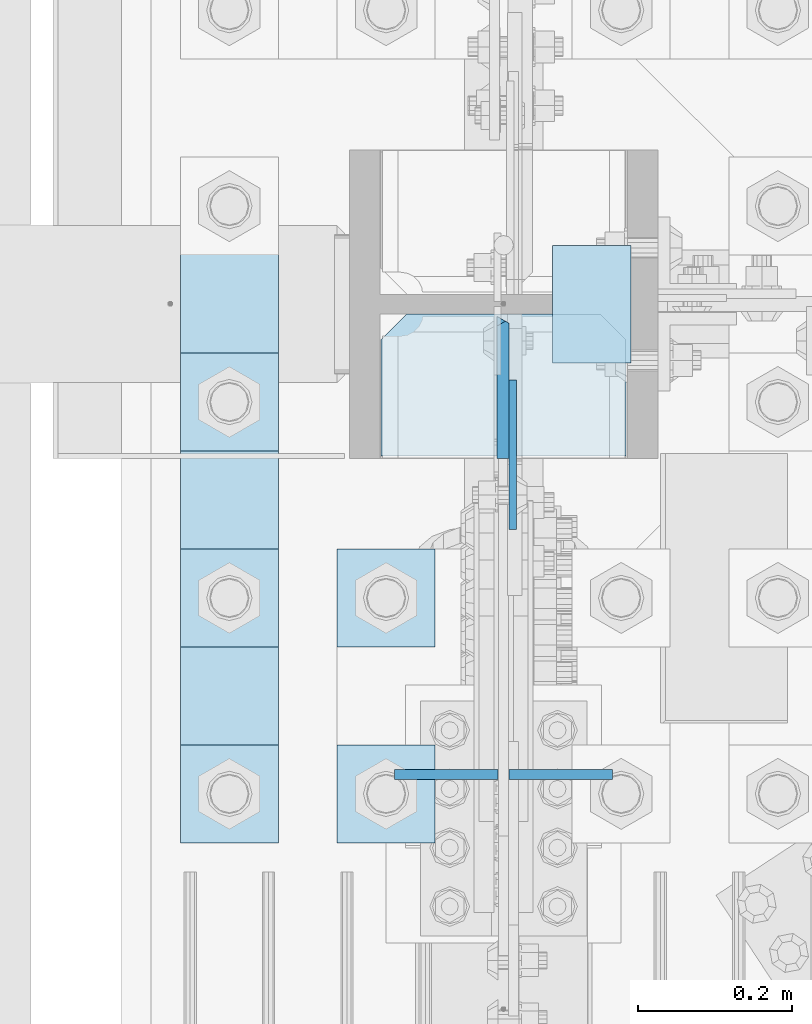
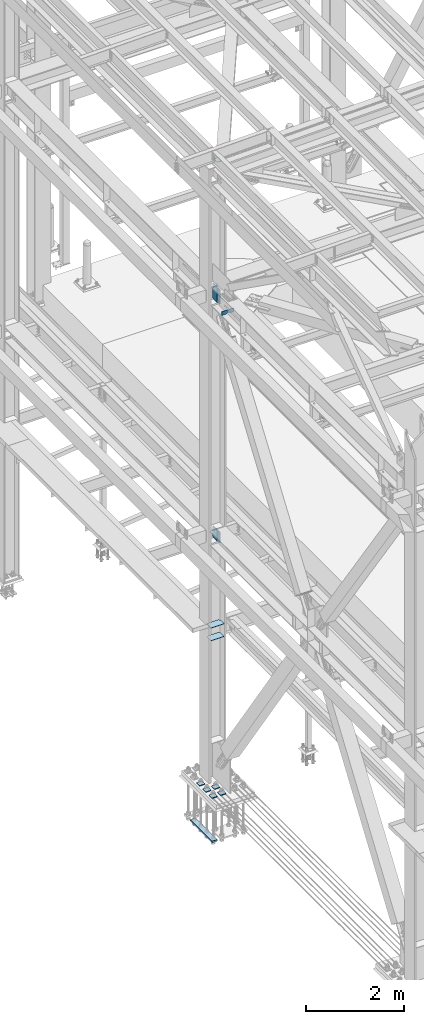
# One storey, part 3361 of 3843: 15 plates, 3 elements without a shape of their own.
"""IFC2X3 building model written with IfcOpenShell, lengths in millimetres."""

from ifc_helpers import new_model, si_unit, frame, origin_with_axes, place, context, subcontext, project, spatial, faceted_brep, material, type_object, element, aggregate, save


model = new_model("IFC2X3")

# Units and contexts
model_context = context("Model", 3, precision=1e-05, world=origin_with_axes())
body_context = subcontext(model_context, "Body", "Model", "MODEL_VIEW")
ifc_project = project(units=[si_unit("LENGTHUNIT", "METRE", prefix="MILLI"), si_unit("AREAUNIT", "SQUARE_METRE"), si_unit("VOLUMEUNIT", "CUBIC_METRE"), si_unit("MASSUNIT", "GRAM", prefix="KILO"), si_unit("TIMEUNIT", "SECOND"), si_unit("PLANEANGLEUNIT", "RADIAN"), si_unit("SOLIDANGLEUNIT", "STERADIAN"), si_unit("THERMODYNAMICTEMPERATUREUNIT", "DEGREE_CELSIUS"), si_unit("LUMINOUSINTENSITYUNIT", "LUMEN")], contexts=[model_context])

# Site, building, storey
site_placement = place(None, origin_with_axes())
site = spatial("IfcSite", under=ifc_project, at=site_placement, CompositionType="ELEMENT")
building_placement = place(site_placement, origin_with_axes())
building = spatial("IfcBuilding", under=site, at=building_placement, Name="Undefined", CompositionType="ELEMENT")
storey_placement = place(building_placement, origin_with_axes())
storey = spatial("IfcBuildingStorey", under=building, at=storey_placement, Name="Undefined", CompositionType="ELEMENT", Elevation=0.0)

# Assembly, plate
assembly_1_placement = place(storey_placement, origin_with_axes())
assembly_1 = element("IfcElementAssembly", 1, at=assembly_1_placement, inside=storey, Name="COLUMN", AssemblyPlace="NOTDEFINED", PredefinedType="RIGID_FRAME")
ifc_material = material(Name="STEEL/A572-50")
plate_type_1 = type_object("IfcPlateType", PredefinedType="NOTDEFINED")
plate_1_placement = place(assembly_1_placement, frame((36639.5, 75704.7000000002, 45422.542188), z_axis=(1.0, 0.0, 0.0), x_axis=(0.0, -1.0, 0.0)))
plate_1 = element("IfcPlate", 2, at=plate_1_placement, type_object=plate_type_1, material=ifc_material, Name="PLATE", context=body_context, shape_type="Brep", body=[
    faceted_brep([(0.0, -3.17499999999927, 0.0), (0.0, -3.17499999999927, 101.600000000006), (0.0, 3.17499999999927, 101.600000000006), (0.0, 3.17499999999927, 0.0), (152.399998474109, -3.17500000000291, 101.599998474121), (152.399998474109, 3.17500000000291, 101.599998474121), (152.399998474109, -3.17500000000291, 0.0), (152.399998474109, 3.17500000000291, 0.0)], [[[0, 1, 2, 3]], [[1, 4, 5, 2]], [[4, 6, 7, 5]], [[6, 0, 3, 7]], [[5, 7, 3, 2]], [[6, 4, 1, 0]]]),
])

# Assembly, plates
assembly_2_placement = place(storey_placement, origin_with_axes())
assembly_2 = element("IfcElementAssembly", 3, at=assembly_2_placement, inside=storey, Name="BEAM", AssemblyPlace="NOTDEFINED", PredefinedType="RIGID_FRAME")
plate_type_2 = type_object("IfcPlateType", PredefinedType="NOTDEFINED")
plate_2_placement = place(assembly_2_placement, frame((36583.14375, 75018.7760854391, 42110.025), z_axis=(0.0, 0.0, -1.0), x_axis=(1.0, 0.0, 0.0)))
plate_2 = element("IfcPlate", 4, at=plate_2_placement, type_object=plate_type_2, material=ifc_material, Name="PLATE", context=body_context, shape_type="Brep", body=[
    faceted_brep([(0.0, -6.3499999046162, 0.0), (0.0, -6.34999999999854, 66.6750000000029), (0.0, 6.34999999999854, 66.6750000000029), (7.27595761418343e-12, 6.3499999046162, 0.0), (25.3999996185303, -6.34999999999854, 92.0749999999971), (25.3999996185303, 6.34999999999854, 92.0749999999971), (134.143749999996, -6.34999999999854, 92.0749999999971), (134.143749999996, 6.34999999999854, 92.0749999999971), (134.143749999996, -6.34999999999854, 0.0), (134.143749999996, 6.34999999999854, 0.0)], [[[0, 1, 2, 3]], [[1, 4, 5, 2]], [[4, 6, 7, 5]], [[6, 8, 9, 7]], [[8, 0, 3, 9]], [[5, 7, 9, 3, 2]], [[8, 6, 4, 1, 0]]]),
])
plate_3_placement = place(assembly_2_placement, frame((36434.7125, 75018.7760854391, 42110.025), z_axis=(0.0, 0.0, -1.0), x_axis=(1.0, 0.0, 0.0)))
plate_3 = element("IfcPlate", 5, at=plate_3_placement, type_object=plate_type_2, material=ifc_material, Name="PLATE", context=body_context, shape_type="Brep", body=[
    faceted_brep([(0.0, -6.3499999046162, 0.0), (0.0, -6.34999999999854, 92.0749999999971), (0.0, 6.34999999999854, 92.0749999999971), (7.27595761418343e-12, 6.3499999046162, 0.0), (108.743750381465, -6.34999999999854, 92.0749999999971), (108.743750381465, 6.34999999999854, 92.0749999999971), (134.143749999996, -6.34999999999854, 66.6750003814668), (134.143749999996, 6.34999999999854, 66.6750003814668), (134.143749999996, -6.34999999999854, 0.0), (134.143749999996, 6.34999999999854, 0.0)], [[[0, 1, 2, 3]], [[1, 4, 5, 2]], [[4, 6, 7, 5]], [[6, 8, 9, 7]], [[8, 0, 3, 9]], [[5, 7, 9, 3, 2]], [[8, 6, 4, 1, 0]]]),
])
aggregate(assembly_2, [plate_2, plate_3])

# Plate
plate_type_3 = type_object("IfcPlateType", PredefinedType="NOTDEFINED")
plate_4_placement = place(assembly_1_placement, frame((36587.90625, 75336.400001526, 42411.65), z_axis=(0.0, 0.0, -1.0), x_axis=(0.0, 1.0, 0.0)))
plate_4 = element("IfcPlate", 6, at=plate_4_placement, type_object=plate_type_3, material=ifc_material, Name="PLATE", context=body_context, shape_type="Brep", body=[
    faceted_brep([(0.0, -4.76249999999709, 0.0), (0.0, -4.76249999999709, 358.774999999994), (0.0, 4.76249999999709, 358.774999999994), (0.0, 4.76249999999709, 0.0), (193.674999999996, -4.76249999999709, 358.774999999994), (193.674999999996, 4.76249999999709, 358.774999999994), (193.674999999996, -4.76249999999709, 0.0), (193.674999999996, 4.76249999999709, 0.0)], [[[0, 1, 2, 3]], [[1, 4, 5, 2]], [[4, 6, 7, 5]], [[6, 0, 3, 7]], [[5, 7, 3, 2]], [[6, 4, 1, 0]]]),
])

plate_5_placement = place(assembly_1_placement, frame((36587.90625, 75336.400001526, 36387.0875), z_axis=(0.0, 0.0, -1.0), x_axis=(0.0, 1.0, 0.0)))
plate_5 = element("IfcPlate", 7, at=plate_5_placement, type_object=plate_type_3, material=ifc_material, Name="PLATE", context=body_context, shape_type="Brep", body=[
    faceted_brep([(0.0, -4.76249999999709, 0.0), (1.45519152283669e-11, -4.76249999999709, 269.874990844721), (1.45519152283669e-11, 4.76249999999709, 269.874990844721), (0.0, 4.76249999999709, 0.0), (193.675000000003, -4.76249999999709, 269.874990844721), (193.675000000003, 4.76249999999709, 269.874990844721), (193.674999999996, -4.76249999999709, 0.0), (193.674999999996, 4.76249999999709, 0.0)], [[[0, 1, 2, 3]], [[1, 4, 5, 2]], [[4, 6, 7, 5]], [[6, 0, 3, 7]], [[5, 7, 3, 2]], [[6, 4, 1, 0]]]),
])

plate_type_4 = type_object("IfcPlateType", PredefinedType="NOTDEFINED")
plate_6_placement = place(assembly_1_placement, frame((36575.20625, 75615.7999999997, 42049.7000027761), z_axis=(0.0, -0.707106781186682, 0.707106781186413), x_axis=(0.0, -0.707106781186548, -0.707106781186548)))
plate_6 = element("IfcPlate", 8, at=plate_6_placement, type_object=plate_type_4, material=ifc_material, Name="PLATE", context=body_context, shape_type="Brep", body=[
    faceted_brep([(4.49012799309094, -7.9375, 7.27595761418343e-12), (-258.182363479666, -7.9375, 262.67249147276), (-258.182363479666, 3.06102272230783, 271.652747647553), (-254.200736443892, 7.9375, 271.652747659136), (13.470384184775, 7.9375, 3.98162703046546), (13.4703841731916, 3.06102272879798, -7.27595761418343e-12), (-258.182363479651, -7.9375, 280.633003845527), (-136.94890581214, -7.9375, 401.866457350838), (-130.467612416716, 7.93750000095315, 395.385867526324), (22.4506403026729, -7.93750001103617, 0.0), (137.203156367104, 7.9375, 127.714399254661), (143.684450000859, -7.93749999986903, 121.233809668522), (124.601054452933, 7.9375, 140.3165009773), (124.601054452933, -7.9375, 140.3165009773), (-117.86586234005, 7.9375, 382.783414159065), (-117.86586234005, -7.9375, 382.783414159065)], [[[0, 1, 2, 3, 4, 5]], [[6, 7, 8, 3, 2]], [[9, 0, 5]], [[10, 11, 9, 5, 4]], [[12, 13, 11, 10]], [[14, 15, 13, 12]], [[15, 14, 8, 7]], [[1, 0, 9, 11, 13, 15, 7, 6]], [[6, 2, 1]], [[8, 14, 12, 10, 4, 3]]]),
])

plate_7_placement = place(assembly_1_placement, frame((36575.20625, 75615.8000000006, 36121.974999999), z_axis=(0.0, -0.707106781186682, 0.707106781186413), x_axis=(0.0, -0.707106781186548, -0.707106781186548)))
plate_7 = element("IfcPlate", 9, at=plate_7_placement, type_object=plate_type_4, material=ifc_material, Name="PLATE", context=body_context, shape_type="Brep", body=[
    faceted_brep([(-180.113623446363, 7.9375, 197.565634661856), (13.470384184775, 7.9375, 3.98162703046546), (13.4703841731916, 3.06102272879798, -7.27595761418343e-12), (4.49012799309094, -7.9375, 7.27595761418343e-12), (-184.095250465922, -7.9375, 188.585378458934), (-184.095250465834, 3.06102272735734, 197.565634661623), (-184.095250465747, -7.9375, 206.545890861955), (-62.8617937965901, -7.9375, 327.779349419703), (-56.3805024344765, 7.93749996326369, 321.298757561868), (22.4506403026729, -7.93750001103617, 0.0), (137.203156367104, 7.9375, 127.714399254661), (143.684450000859, -7.93749999986903, 121.233809668522), (134.703841697788, 7.9375, 130.21371389494), (134.703841697788, -7.9375, 130.21371389494), (-53.8815365549381, 7.9375, 318.799092176701), (-53.8815365549381, -7.9375, 318.799092176701)], [[[0, 1, 2, 3, 4, 5]], [[6, 7, 8, 0, 5]], [[9, 3, 2]], [[10, 11, 9, 2, 1]], [[12, 13, 11, 10]], [[14, 15, 13, 12]], [[15, 14, 8, 7]], [[4, 3, 9, 11, 13, 15, 7, 6]], [[6, 5, 4]], [[8, 14, 12, 10, 1, 0]]]),
])

plate_type_5 = type_object("IfcPlateType", PredefinedType="NOTDEFINED")
plate_8_placement = place(assembly_1_placement, frame((36734.75, 75615.8, 33688.3375), z_axis=(-1.0, 0.0, 0.0), x_axis=(0.0, -1.0, 0.0)))
plate_8 = element("IfcPlate", 10, at=plate_8_placement, type_object=plate_type_5, material=ifc_material, Name="PLATE", context=body_context, shape_type="Brep", body=[
    faceted_brep([(0.0, -4.76249999999709, 33.3375015258789), (0.0, -4.76249999999709, 284.162498474121), (0.0, 4.76249999999709, 284.162498474121), (0.0, 4.76249999999709, 33.3375015258789), (33.3375015258789, -4.76249999999709, 317.5), (33.3375015258789, 4.76249999999709, 317.5), (184.150000000009, -4.76249999999709, 317.5), (184.150000000009, 4.76249999999709, 317.5), (184.150000000009, -4.76249999999709, 0.0), (184.150000000009, 4.76249999999709, 0.0), (33.3375015258789, -4.76249999999709, 0.0), (33.3375015258789, 4.76249999999709, 0.0)], [[[0, 1, 2, 3]], [[1, 4, 5, 2]], [[4, 6, 7, 5]], [[6, 8, 9, 7]], [[8, 10, 11, 9]], [[10, 0, 3, 11]], [[5, 7, 9, 11, 3, 2]], [[10, 8, 6, 4, 1, 0]]]),
])

plate_9_placement = place(assembly_1_placement, frame((36734.75, 75615.8, 34002.6625), z_axis=(-1.0, 0.0, 0.0), x_axis=(0.0, -1.0, 0.0)))
plate_9 = element("IfcPlate", 11, at=plate_9_placement, type_object=plate_type_5, material=ifc_material, Name="PLATE", context=body_context, shape_type="Brep", body=[
    faceted_brep([(0.0, -4.76249999999709, 33.3375015258789), (0.0, -4.76249999999709, 284.162498474121), (0.0, 4.76249999999709, 284.162498474121), (0.0, 4.76249999999709, 33.3375015258789), (33.3375015258789, -4.76249999999709, 317.5), (33.3375015258789, 4.76249999999709, 317.5), (184.150000000009, -4.76249999999709, 317.5), (184.150000000009, 4.76249999999709, 317.5), (184.150000000009, -4.76249999999709, 0.0), (184.150000000009, 4.76249999999709, 0.0), (33.3375015258789, -4.76249999999709, 0.0), (33.3375015258789, 4.76249999999709, 0.0)], [[[0, 1, 2, 3]], [[1, 4, 5, 2]], [[4, 6, 7, 5]], [[6, 8, 9, 7]], [[8, 10, 11, 9]], [[10, 0, 3, 11]], [[5, 7, 9, 11, 3, 2]], [[10, 8, 6, 4, 1, 0]]]),
])

aggregate(assembly_1, [plate_1, plate_4, plate_6, plate_5, plate_7, plate_8, plate_9])

# Assembly, plates
assembly_3_placement = place(storey_placement, origin_with_axes())
assembly_3 = element("IfcElementAssembly", 12, at=assembly_3_placement, inside=storey, Name="TEMPLATE", AssemblyPlace="NOTDEFINED", PredefinedType="RIGID_FRAME")
plate_type_6 = type_object("IfcPlateType", PredefinedType="NOTDEFINED")
plate_10_placement = place(assembly_3_placement, frame((36360.1, 75057.0, 30172.025), z_axis=(0.0, -1.0, 0.0), x_axis=(1.0, 0.0, 0.0)))
plate_10 = element("IfcPlate", 13, at=plate_10_placement, type_object=plate_type_6, material=ifc_material, Name="Washer Plate", context=body_context, shape_type="Brep", body=[
    faceted_brep([(0.0, -9.52500000000146, 0.0), (0.0, -9.52499999999418, 127.0), (0.0, 9.52499999999418, 127.0), (0.0, 9.52500000000146, 0.0), (127.0, -9.52500000000146, 127.0), (127.0, 9.52500000000146, 127.0), (127.0, -9.52500000000146, 0.0), (127.0, 9.52500000000146, 0.0)], [[[0, 1, 2, 3]], [[1, 4, 5, 2]], [[4, 6, 7, 5]], [[6, 0, 3, 7]], [[5, 7, 3, 2]], [[6, 4, 1, 0]]]),
])
plate_11_placement = place(assembly_3_placement, frame((36360.1, 75311.0, 30172.025), z_axis=(0.0, -1.0, 0.0), x_axis=(1.0, 0.0, 0.0)))
plate_11 = element("IfcPlate", 14, at=plate_11_placement, type_object=plate_type_6, material=ifc_material, Name="Washer Plate", context=body_context, shape_type="Brep", body=[
    faceted_brep([(0.0, -9.52500000000146, 0.0), (0.0, -9.52499999999418, 127.0), (0.0, 9.52499999999418, 127.0), (0.0, 9.52500000000146, 0.0), (127.0, -9.52500000000146, 127.0), (127.0, 9.52500000000146, 127.0), (127.0, -9.52500000000146, 0.0), (127.0, 9.52500000000146, 0.0)], [[[0, 1, 2, 3]], [[1, 4, 5, 2]], [[4, 6, 7, 5]], [[6, 0, 3, 7]], [[5, 7, 3, 2]], [[6, 4, 1, 0]]]),
])
plate_12_placement = place(assembly_3_placement, frame((36156.9, 75057.0, 30172.025), z_axis=(0.0, -1.0, 0.0), x_axis=(1.0, 0.0, 0.0)))
plate_12 = element("IfcPlate", 15, at=plate_12_placement, type_object=plate_type_6, material=ifc_material, Name="Washer Plate", context=body_context, shape_type="Brep", body=[
    faceted_brep([(0.0, -9.52500000000146, 0.0), (0.0, -9.52499999999418, 127.0), (0.0, 9.52499999999418, 127.0), (0.0, 9.52500000000146, 0.0), (127.0, -9.52500000000146, 127.0), (127.0, 9.52500000000146, 127.0), (127.0, -9.52500000000146, 0.0), (127.0, 9.52500000000146, 0.0)], [[[0, 1, 2, 3]], [[1, 4, 5, 2]], [[4, 6, 7, 5]], [[6, 0, 3, 7]], [[5, 7, 3, 2]], [[6, 4, 1, 0]]]),
])
plate_13_placement = place(assembly_3_placement, frame((36156.9, 75311.0, 30172.025), z_axis=(0.0, -1.0, 0.0), x_axis=(1.0, 0.0, 0.0)))
plate_13 = element("IfcPlate", 16, at=plate_13_placement, type_object=plate_type_6, material=ifc_material, Name="Washer Plate", context=body_context, shape_type="Brep", body=[
    faceted_brep([(0.0, -9.52500000000146, 0.0), (0.0, -9.52499999999418, 127.0), (0.0, 9.52499999999418, 127.0), (0.0, 9.52500000000146, 0.0), (127.0, -9.52500000000146, 127.0), (127.0, 9.52500000000146, 127.0), (127.0, -9.52500000000146, 0.0), (127.0, 9.52500000000146, 0.0)], [[[0, 1, 2, 3]], [[1, 4, 5, 2]], [[4, 6, 7, 5]], [[6, 0, 3, 7]], [[5, 7, 3, 2]], [[6, 4, 1, 0]]]),
])
plate_14_placement = place(assembly_3_placement, frame((36156.9, 75565.0, 30172.025), z_axis=(0.0, -1.0, 0.0), x_axis=(1.0, 0.0, 0.0)))
plate_14 = element("IfcPlate", 17, at=plate_14_placement, type_object=plate_type_6, material=ifc_material, Name="Washer Plate", context=body_context, shape_type="Brep", body=[
    faceted_brep([(0.0, -9.52500000000146, 0.0), (0.0, -9.52499999999418, 127.0), (0.0, 9.52499999999418, 127.0), (0.0, 9.52500000000146, 0.0), (127.0, -9.52500000000146, 127.0), (127.0, 9.52500000000146, 127.0), (127.0, -9.52500000000146, 0.0), (127.0, 9.52500000000146, 0.0)], [[[0, 1, 2, 3]], [[1, 4, 5, 2]], [[4, 6, 7, 5]], [[6, 0, 3, 7]], [[5, 7, 3, 2]], [[6, 4, 1, 0]]]),
])
plate_type_7 = type_object("IfcPlateType", PredefinedType="NOTDEFINED")
plate_15_placement = place(assembly_3_placement, frame((36156.9, 75819.0, 29089.35), z_axis=(0.0, -1.0, 0.0), x_axis=(1.0, 0.0, 0.0)))
plate_15 = element("IfcPlate", 18, at=plate_15_placement, type_object=plate_type_7, material=ifc_material, Name="PLATE", context=body_context, shape_type="Brep", body=[
    faceted_brep([(0.0, -19.0500000000029, 0.0), (-7.27595761418343e-12, -19.0499999999993, 889.0), (-7.27595761418343e-12, 19.0499999999993, 889.0), (0.0, 19.0500000000029, 0.0), (127.0, -19.0499999999993, 889.0), (127.0, 19.0499999999993, 889.0), (127.0, -19.0499999999993, 0.0), (127.0, 19.0499999999993, 0.0)], [[[0, 1, 2, 3]], [[1, 4, 5, 2]], [[4, 6, 7, 5]], [[6, 0, 3, 7]], [[5, 7, 3, 2]], [[6, 4, 1, 0]]]),
])
aggregate(assembly_3, [plate_10, plate_11, plate_12, plate_13, plate_14, plate_15])

save(model, "model.ifc")
